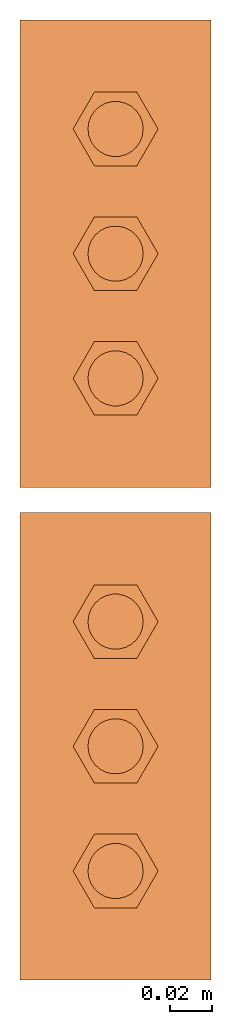
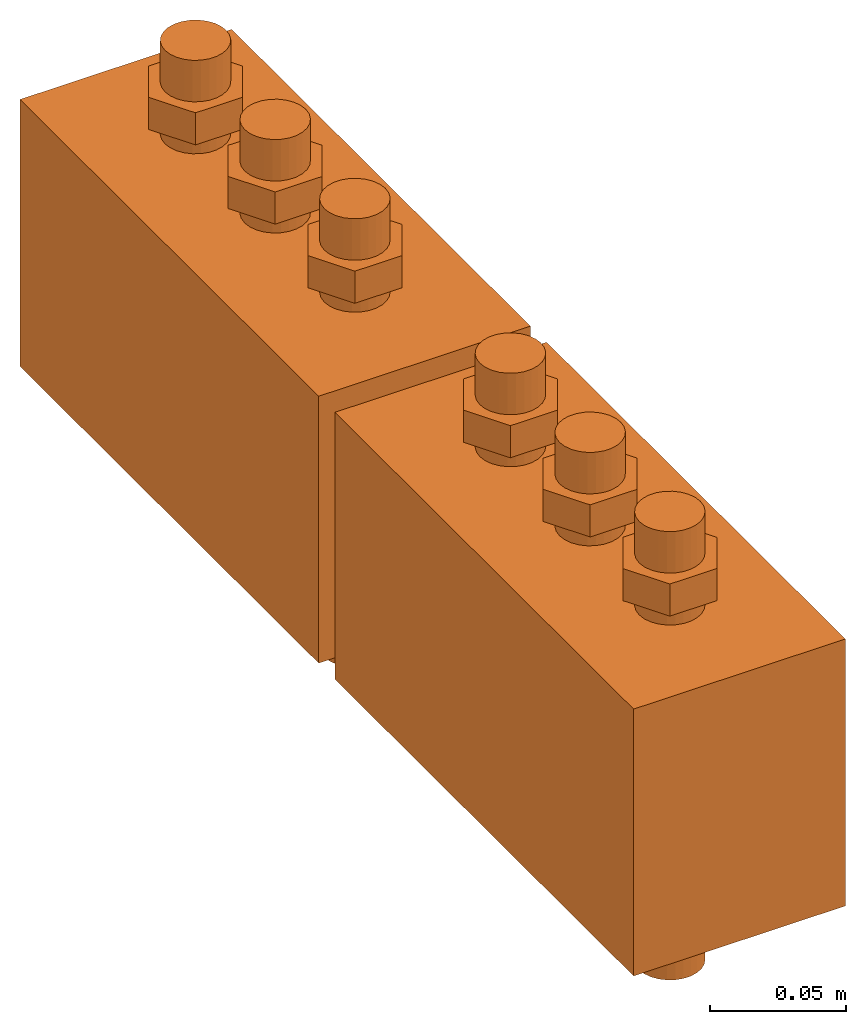
# One storey: 2 proxies.
"""IFC2X3 building model written with IfcOpenShell, lengths in millimetres."""

from ifc_helpers import new_model, entity, si_unit, converted_unit, derived_unit, direction, frame, frame_2d, origin, place, context, subcontext, project, spatial, polyline, rectangle, circle, outline, extrude, source, transform, mapped, material, material_list, type_object, type_shapes, element, save


model = new_model("IFC2X3")

# Units and contexts
model_context = context("Model", 3, precision=0.01, world=origin(), true_north=direction((6.12303176911189e-17, 1.0)))
body_context = subcontext(model_context, "Body", "Model", "MODEL_VIEW")
ifc_project = project(units=[si_unit("LENGTHUNIT", "METRE", prefix="MILLI"), si_unit("AREAUNIT", "SQUARE_METRE"), si_unit("VOLUMEUNIT", "CUBIC_METRE"), converted_unit("PLANEANGLEUNIT", "DEGREE", entity("IfcRatioMeasure", 0.0174532925199433), si_unit("PLANEANGLEUNIT", "RADIAN"), dimensions=[0, 0, 0, 0, 0, 0, 0]), si_unit("MASSUNIT", "GRAM", prefix="KILO"), derived_unit("MASSDENSITYUNIT", [(si_unit("MASSUNIT", "GRAM", prefix="KILO"), 1), (si_unit("LENGTHUNIT", "METRE"), -3)]), derived_unit("MOMENTOFINERTIAUNIT", [(si_unit("LENGTHUNIT", "METRE"), 4)]), si_unit("TIMEUNIT", "SECOND"), si_unit("FREQUENCYUNIT", "HERTZ"), si_unit("THERMODYNAMICTEMPERATUREUNIT", "DEGREE_CELSIUS"), derived_unit("THERMALTRANSMITTANCEUNIT", [(si_unit("MASSUNIT", "GRAM", prefix="KILO"), 1), (si_unit("THERMODYNAMICTEMPERATUREUNIT", "KELVIN"), -1), (si_unit("TIMEUNIT", "SECOND"), -3)]), derived_unit("VOLUMETRICFLOWRATEUNIT", [(si_unit("LENGTHUNIT", "METRE"), 3), (si_unit("TIMEUNIT", "SECOND"), -1)]), derived_unit("MASSFLOWRATEUNIT", [(si_unit("MASSUNIT", "GRAM", prefix="KILO"), 1), (si_unit("TIMEUNIT", "SECOND"), -1)]), derived_unit("ROTATIONALFREQUENCYUNIT", [(si_unit("TIMEUNIT", "SECOND"), -1)]), si_unit("ELECTRICCURRENTUNIT", "AMPERE"), si_unit("ELECTRICVOLTAGEUNIT", "VOLT"), si_unit("POWERUNIT", "WATT"), si_unit("FORCEUNIT", "NEWTON", prefix="KILO"), si_unit("ILLUMINANCEUNIT", "LUX"), si_unit("LUMINOUSFLUXUNIT", "LUMEN"), si_unit("LUMINOUSINTENSITYUNIT", "CANDELA"), derived_unit("USERDEFINED", [(si_unit("MASSUNIT", "GRAM", prefix="KILO"), -1), (si_unit("LENGTHUNIT", "METRE"), -2), (si_unit("TIMEUNIT", "SECOND"), 3), (si_unit("LUMINOUSFLUXUNIT", "LUMEN"), 1)]), derived_unit("LINEARVELOCITYUNIT", [(si_unit("LENGTHUNIT", "METRE"), 1), (si_unit("TIMEUNIT", "SECOND"), -1)]), si_unit("PRESSUREUNIT", "PASCAL"), derived_unit("USERDEFINED", [(si_unit("LENGTHUNIT", "METRE"), -2), (si_unit("MASSUNIT", "GRAM", prefix="KILO"), 1), (si_unit("TIMEUNIT", "SECOND"), -2)]), derived_unit("LINEARFORCEUNIT", [(si_unit("MASSUNIT", "GRAM", prefix="KILO"), 1), (si_unit("LENGTHUNIT", "METRE"), 1), (si_unit("TIMEUNIT", "SECOND"), -2), (si_unit("LENGTHUNIT", "METRE"), -1)]), derived_unit("PLANARFORCEUNIT", [(si_unit("MASSUNIT", "GRAM", prefix="KILO"), 1), (si_unit("LENGTHUNIT", "METRE"), 1), (si_unit("TIMEUNIT", "SECOND"), -2), (si_unit("LENGTHUNIT", "METRE"), -2)])], contexts=[model_context])

# Site, building, storey
site_placement = place(None, frame((0.0, 2493.83037508239, 0.0)))
site = spatial("IfcSite", under=ifc_project, at=site_placement, CompositionType="ELEMENT")
building_placement = place(site_placement, origin())
building = spatial("IfcBuilding", under=site, at=building_placement, CompositionType="ELEMENT")
storey_placement = place(building_placement, frame((0.0, 0.0, 24000.0)))
storey = spatial("IfcBuildingStorey", under=building, at=storey_placement, Name="07", CompositionType="ELEMENT", Elevation=24000.0)

# Proxies
ifc_material = material()
ifc_material_list = material_list([ifc_material, ifc_material, ifc_material, ifc_material, ifc_material, ifc_material, ifc_material, ifc_material, ifc_material, ifc_material])
building_element_proxy_type = type_object("IfcBuildingElementProxyType", PredefinedType="NOTDEFINED", material=ifc_material_list)
shared_shape = source(origin(), body_context, "Body", "SweptSolid", [
    extrude(outline(polyline([(-10.0, -17.3205080756888), (10.0, -17.3205080756888), (20.0, 0.0), (10.0, 17.3205080756888), (-10.0, 17.3205080756888), (-20.0, 0.0), (-10.0, -17.3205080756888)])), frame((0.0, 58.6966128400503, -22.9668413157841), z_axis=(0.0, 0.0, 1.0), x_axis=(-1.0, 0.0, 0.0)), (0.0, 0.0, 1.0), 14.4431951373194),
    extrude(outline(polyline([(-10.0, -17.3205080756888), (10.0, -17.3205080756888), (20.0, 0.0), (10.0, 17.3205080756888), (-10.0, 17.3205080756888), (-20.0, 0.0), (-10.0, -17.3205080756888)])), frame((0.0, 0.0, -22.9668413157841), z_axis=(0.0, 0.0, 1.0), x_axis=(-1.0, 0.0, 0.0)), (0.0, 0.0, 1.0), 14.4431951373194),
    extrude(outline(polyline([(-10.0, -17.3205080756888), (10.0, -17.3205080756888), (20.0, 0.0), (10.0, 17.3205080756888), (-10.0, 17.3205080756888), (-20.0, 0.0), (-10.0, -17.3205080756888)])), frame((0.0, -58.6966128400498, -22.9668413157841), z_axis=(0.0, 0.0, 1.0), x_axis=(-1.0, 0.0, 0.0)), (0.0, 0.0, 1.0), 14.4431951373194),
    extrude(outline(polyline([(-10.0, -17.3205080756888), (10.0, -17.3205080756888), (20.0, 0.0), (10.0, 17.3205080756888), (-10.0, 17.3205080756888), (-20.0, 0.0), (-10.0, -17.3205080756888)])), frame((0.0, 58.6966128400503, 128.908158684216), z_axis=(0.0, 0.0, 1.0), x_axis=(-1.0, 0.0, 0.0)), (0.0, 0.0, 1.0), 14.4431951373194),
    extrude(outline(polyline([(-10.0, -17.3205080756888), (10.0, -17.3205080756888), (20.0, 0.0), (10.0, 17.3205080756888), (-10.0, 17.3205080756888), (-20.0, 0.0), (-10.0, -17.3205080756888)])), frame((0.0, 0.0, 128.908158684216), z_axis=(0.0, 0.0, 1.0), x_axis=(-1.0, 0.0, 0.0)), (0.0, 0.0, 1.0), 14.4431951373194),
    extrude(outline(polyline([(-10.0, -17.3205080756888), (10.0, -17.3205080756888), (20.0, 0.0), (10.0, 17.3205080756888), (-10.0, 17.3205080756888), (-20.0, 0.0), (-10.0, -17.3205080756888)])), frame((0.0, -58.6966128400498, 128.908158684216), z_axis=(0.0, 0.0, 1.0), x_axis=(-1.0, 0.0, 0.0)), (0.0, 0.0, 1.0), 14.4431951373194),
    extrude(circle(Radius=13.0, at=frame_2d((-4.34191362547739e-16, -2.53796983429311e-14), x_axis=(1.0, 0.0))), frame((0.0, -58.6966128400498, -39.5699827462825)), (0.0, 0.0, 1.0), 201.570672959406),
    extrude(circle(Radius=13.0, at=frame_2d((-8.62966389568707e-16, -1.69197988952874e-14), x_axis=(1.0, 0.0))), frame((0.0, 58.6966128400504, -39.5699827462825)), (0.0, 0.0, 1.0), 201.570672959406),
    extrude(circle(Radius=13.0, at=frame_2d((-7.81065737226291e-16, -2.10020794676236e-14), x_axis=(1.0, 0.0))), frame((0.0, 0.0, -39.5699827462825)), (0.0, 0.0, 1.0), 201.570672959406),
    extrude(rectangle(XDim=220.0, YDim=90.0000000000004, at=frame_2d((7.105427357601e-15, 9.2370555648813e-14), x_axis=(1.0, 0.0))), frame((0.0, 0.0, 0.0), z_axis=(0.0, 0.0, 1.0), x_axis=(0.0, -1.0, 0.0)), (0.0, 0.0, 1.0), 120.0),
])
type_shapes(building_element_proxy_type, [shared_shape])
for number, where in (
    (1, (71315.1118832777, 14175.7114721327, 0.0)),
    (2, (71315.1118832777, 13943.784457028, 0.0)),
):
    element("IfcBuildingElementProxy", number, at=place(storey_placement, frame(where)), inside=storey, type_object=building_element_proxy_type, material=ifc_material, context=body_context, shape_type="MappedRepresentation", body=[
        mapped(shared_shape, transform((0.0, 0.0, 0.0), scale=1.0)),
    ])

save(model, "model.ifc")
